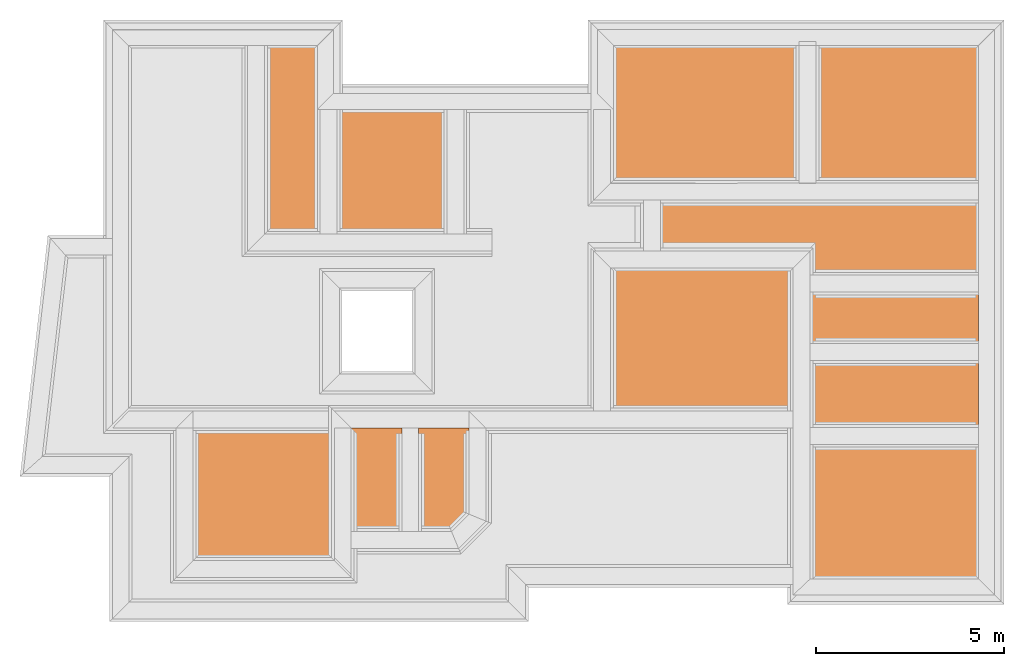
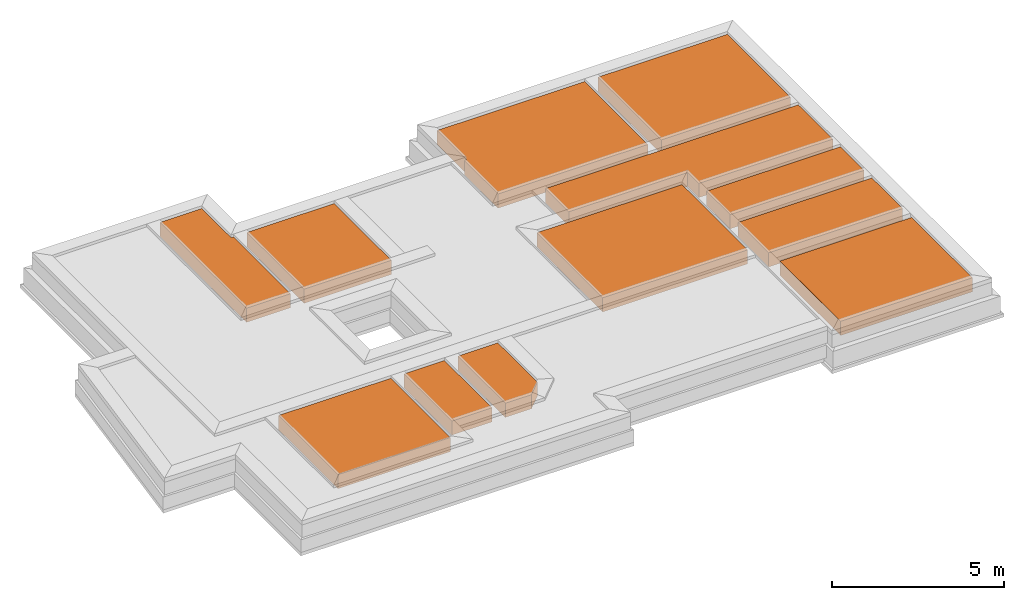
# One storey, part 5 of 6: 10 earthworks fills, 2 built elements.
"""IFC4X3_ADD2 building model written with IfcOpenShell, lengths in metres."""

from ifc_helpers import new_model, entity, si_unit, converted_unit, frame, origin_with_axes, origin_2d_with_axis, place, context, subcontext, project, spatial, indexed_curve, outline, extrude, polygons, material, layer, layer_set, layer_usage, type_object, element, save


model = new_model("IFC4X3_ADD2")

# Units and contexts
model_context = context("Model", 3, precision=1e-05, world=origin_with_axes())
plan_context = context("Plan", 2, precision=1e-05, world=origin_2d_with_axis())
body_context = subcontext(model_context, "Body", "Model", "MODEL_VIEW")
ifc_project = project(units=[si_unit("VOLUMEUNIT", "CUBIC_METRE"), si_unit("LENGTHUNIT", "METRE"), converted_unit("PLANEANGLEUNIT", "degree", entity("IfcReal", 0.0174532925199433), si_unit("PLANEANGLEUNIT", "RADIAN"), dimensions=[0, 0, 0, 0, 0, 0, 0]), si_unit("AREAUNIT", "SQUARE_METRE")], contexts=[model_context, plan_context])

# Site, building, storey
site_placement = place(None, origin_with_axes())
site = spatial("IfcSite", under=ifc_project, at=site_placement)
building_placement = place(site_placement, origin_with_axes())
building = spatial("IfcBuilding", under=site, at=building_placement, Name="Building")
storey_placement = place(building_placement, frame((0.0, 0.0, -0.870000004768372), z_axis=(0.0, 0.0, 1.0), x_axis=(1.0, 0.0, 0.0)))
storey = spatial("IfcBuildingStorey", under=building, at=storey_placement, Name="Footing")

# Built element
ifc_material = material(Name="Brick")
ifc_layer = layer(ifc_material, 0.5)
ifc_layer_set = layer_set([ifc_layer])
ifc_layer_usage = layer_usage(ifc_layer_set, "AXIS3", "POSITIVE", -0.100000001490116)
built_element_type = type_object("IfcBuiltElementType", Name="EarthFill", material=ifc_layer_set)
built_element_1_placement = place(storey_placement, frame((26.6491851806641, 12.8797168731689, 0.820000022649765), z_axis=(0.0, 0.0, 1.0), x_axis=(1.0, 0.0, 0.0)))
element("IfcBuiltElement", 1, at=built_element_1_placement, inside=storey, type_object=built_element_type, material=ifc_layer_usage, Name="BuiltElement", context=body_context, shape_type="SweptSolid", body=[
    extrude(outline(indexed_curve([(1.61248397827148, -1.09536957740784), (1.61248397827148, 2.42463111877441), (-2.79917144775391, 2.42463111877441), (-2.79917144775391, -1.09536957740784), (1.61248397827148, -1.09536957740784)])), frame((0.0, 0.0, -0.100000001490116), z_axis=(0.0, 0.0, 1.0), x_axis=(1.0, 0.0, 0.0)), (0.0, 0.0, 1.0), 0.5),
])

# Earthworks fill
earthworks_fill_1_placement = place(storey_placement, frame((20.5324192047119, 25.557674407959, 0.719999670982361), z_axis=(0.0, 0.0, 1.0), x_axis=(1.0, 0.0, 0.0)))
element("IfcEarthworksFill", 2, at=earthworks_fill_1_placement, inside=storey, Name="Slab", PredefinedType="BACKFILL", context=body_context, shape_type="Tessellation", body=[
    polygons([(3.2425971031189, -7.49831056594849, 0.500000357627869), (3.24265813827515, -6.12808227539062, 0.500000357627869), (7.72924995422363, -6.12808227539062, 0.500000357627869), (3.2425971031189, -7.49831056594849, 0.0), (7.72924995422363, -7.49831056594849, 0.500000357627869), (7.72924995422363, -7.49831056594849, 0.0), (7.72924995422363, -6.12808227539062, 0.0), (3.24265813827515, -6.12808227539062, 0.0)], [[[5, 6, 4, 1]], [[2, 8, 7, 3]], [[1, 4, 8, 2]], [[3, 7, 6, 5]], [[3, 5, 1, 2]], [[6, 7, 8, 4]]]),
])

# Built element
built_element_2_placement = place(storey_placement, frame((5.8589391708374, 28.8824787139893, 0.719999670982361), z_axis=(0.0, 0.0, 1.0), x_axis=(1.0, 0.0, 0.0)))
element("IfcBuiltElement", 3, at=built_element_2_placement, inside=storey, Name="Slab", context=body_context, shape_type="Tessellation", body=[
    polygons([(4.80036449432373, -2.89457559585571, 0.0), (4.80036449432373, -2.89457559585571, 0.500000357627869), (3.39926075935364, -2.89457559585571, 0.500000357627869), (3.39926075935364, -2.89457559585571, 0.0), (3.39919972419739, -7.90809297561646, 0.500000357627869), (3.39919972419739, -7.90809297561646, 0.0), (4.87536239624023, -7.90809297561646, 0.500000357627869), (4.87536239624023, -7.90809297561646, 0.0), (4.87536239624023, -4.59257173538208, 0.500000357627869), (4.87536239624023, -4.59257173538208, 0.0), (4.80036449432373, -4.59257173538208, 0.500000357627869), (4.80036449432373, -4.59257173538208, 0.0)], [[[2, 1, 12, 11]], [[7, 5, 3, 2, 11, 9]], [[3, 4, 1, 2]], [[11, 12, 10, 9]], [[12, 1, 4, 6, 8, 10]], [[7, 8, 6, 5]], [[9, 10, 8, 7]], [[5, 6, 4, 3]]]),
])

# Earthworks fills
earthworks_fill_2_placement = place(storey_placement, frame((15.224084854126, 25.9791069030762, 0.719999670982361), z_axis=(0.0, 0.0, 1.0), x_axis=(1.0, 0.0, 0.0)))
element("IfcEarthworksFill", 4, at=earthworks_fill_2_placement, inside=storey, Name="Slab", PredefinedType="BACKFILL", context=body_context, shape_type="Tessellation", body=[
    polygons([(3.2425971031189, -9.71308326721191, 0.500000357627869), (3.24265813827515, -5.90621185302734, 0.500000357627869), (8.10093116760254, -5.90621185302734, 0.500000357627869), (3.24265813827515, -5.90621185302734, 0.0), (8.10093116760254, -5.90621185302734, 0.0), (8.10093116760254, -9.71308326721191, 0.0), (8.10093116760254, -9.71308326721191, 0.500000357627869), (3.2425971031189, -9.71308326721191, 0.0)], [[[6, 7, 3, 5]], [[8, 1, 7, 6]], [[5, 3, 2, 4]], [[3, 7, 1, 2]], [[4, 2, 1, 8]], [[6, 5, 4, 8]]]),
])
earthworks_fill_3_placement = place(storey_placement, frame((15.7524299621582, 30.2359886169434, 0.719999670982361), z_axis=(0.0, 0.0, 1.0), x_axis=(1.0, 0.0, 0.0)))
element("IfcEarthworksFill", 5, at=earthworks_fill_3_placement, inside=storey, Name="Slab", PredefinedType="BACKFILL", context=body_context, shape_type="Tessellation", body=[
    polygons([(2.78925061225891, -4.23808860778809, 0.500000357627869), (2.78925061225891, -4.23808860778809, 0.0), (7.72924995422363, -4.23808860778809, 0.0), (7.72924995422363, -4.23808860778809, 0.500000357627869), (7.72924995422363, -7.90809297561646, 0.0), (7.72924995422363, -7.90809297561646, 0.500000357627869), (2.71425199508667, -7.90809297561646, 0.0), (2.71425199508667, -7.90809297561646, 0.500000357627869), (2.71426725387573, -5.94608306884766, 0.0), (2.71426725387573, -5.94608306884766, 0.500000357627869), (2.78922009468079, -5.94608306884766, 0.0), (2.78922009468079, -5.94608306884766, 0.500000357627869)], [[[3, 2, 11, 9, 7, 5]], [[2, 1, 12, 11]], [[5, 6, 4, 3]], [[3, 4, 1, 2]], [[11, 12, 10, 9]], [[7, 8, 6, 5]], [[6, 8, 10, 12, 1, 4]], [[9, 10, 8, 7]]]),
])
earthworks_fill_4_placement = place(storey_placement, frame((20.5324192047119, 30.2359886169434, 0.719999670982361), z_axis=(0.0, 0.0, 1.0), x_axis=(1.0, 0.0, 0.0)))
element("IfcEarthworksFill", 6, at=earthworks_fill_4_placement, inside=storey, Name="Slab", PredefinedType="BACKFILL", context=body_context, shape_type="Tessellation", body=[
    polygons([(3.39919972419739, -7.90809297561646, 0.500000357627869), (3.39926075935364, -4.23808860778809, 0.500000357627869), (7.72924995422363, -4.23808860778809, 0.500000357627869), (3.39919972419739, -7.90809297561646, 0.0), (7.72924995422363, -7.90809297561646, 0.500000357627869), (7.72924995422363, -7.90809297561646, 0.0), (7.72924995422363, -4.23808860778809, 0.0), (3.39926075935364, -4.23808860778809, 0.0)], [[[1, 4, 8, 2]], [[2, 8, 7, 3]], [[3, 5, 1, 2]], [[5, 6, 4, 1]], [[3, 7, 6, 5]], [[6, 7, 8, 4]]]),
])
earthworks_fill_5_placement = place(storey_placement, frame((30.3727493286133, 25.2770919799805, 0.720000624656678), z_axis=(0.0, 0.0, 1.0), x_axis=(7.54979012640431e-08, -0.999999999999997, 0.0)))
element("IfcEarthworksFill", 7, at=earthworks_fill_5_placement, inside=storey, Name="Slab", PredefinedType="BACKFILL", context=body_context, shape_type="Tessellation", body=[
    polygons([(5.39749765396118, -6.59773302078247, 0.500000357627869), (5.39749765396118, -6.59773302078247, 0.0), (4.75419616699219, -6.59773302078247, 0.0), (4.75419616699219, -6.59773302078247, 0.500000357627869), (4.75419616699219, -10.5810642242432, 0.0), (4.75419616699219, -10.5810642242432, 0.500000357627869), (3.39919948577881, -10.5810642242432, 0.0), (3.39919948577881, -10.5810642242432, 0.500000357627869), (3.39926075935364, -2.11107873916626, 0.0), (3.39926075935364, -2.11107873916626, 0.500000357627869), (5.39749765396118, -2.11107873916626, 0.0), (5.39749765396118, -2.11107873916626, 0.500000357627869)], [[[2, 1, 12, 11]], [[3, 4, 1, 2]], [[5, 6, 4, 3]], [[7, 8, 6, 5]], [[8, 10, 12, 1, 4, 6]], [[9, 10, 8, 7]], [[9, 7, 5, 3, 2, 11]], [[11, 12, 10, 9]]]),
])
earthworks_fill_6_placement = place(storey_placement, frame((3.95439720153809, 20.269115447998, 0.719999670982361), z_axis=(0.0, 0.0, 1.0), x_axis=(1.0, 0.0, 0.0)))
element("IfcEarthworksFill", 8, at=earthworks_fill_6_placement, inside=storey, Name="Slab", PredefinedType="BACKFILL", context=body_context, shape_type="Tessellation", body=[
    polygons([(3.39919972419739, -7.90809297561646, 0.500000357627869), (3.39926075935364, -4.45309543609619, 0.500000357627869), (7.15860080718994, -4.45309543609619, 0.500000357627869), (3.39919972419739, -7.90809297561646, 0.0), (7.15860080718994, -7.90809297561646, 0.500000357627869), (7.15860080718994, -7.90809297561646, 0.0), (7.15860080718994, -4.45309543609619, 0.0), (3.39926075935364, -4.45309543609619, 0.0)], [[[6, 7, 8, 4]], [[3, 5, 1, 2]], [[2, 8, 7, 3]], [[5, 6, 4, 1]], [[3, 7, 6, 5]], [[1, 4, 8, 2]]]),
])
earthworks_fill_7_placement = place(storey_placement, frame((7.7851037979126, 28.8824787139893, 0.719999670982361), z_axis=(0.0, 0.0, 1.0), x_axis=(1.0, 0.0, 0.0)))
element("IfcEarthworksFill", 9, at=earthworks_fill_7_placement, inside=storey, Name="Slab", PredefinedType="BACKFILL", context=body_context, shape_type="Tessellation", body=[
    polygons([(3.39919972419739, -7.90809297561646, 0.500000357627869), (3.39926075935364, -4.59257173538208, 0.500000357627869), (6.32511425018311, -4.59257173538208, 0.500000357627869), (3.39926075935364, -4.59257173538208, 0.0), (6.32511425018311, -4.59257173538208, 0.0), (6.32511425018311, -7.90809297561646, 0.0), (6.32511425018311, -7.90809297561646, 0.500000357627869), (3.39919972419739, -7.90809297561646, 0.0)], [[[6, 5, 4, 8]], [[8, 1, 7, 6]], [[5, 3, 2, 4]], [[6, 7, 3, 5]], [[3, 7, 1, 2]], [[4, 2, 1, 8]]]),
])
earthworks_fill_8_placement = place(storey_placement, frame((7.53807640075684, 20.269115447998, 0.719999670982361), z_axis=(0.0, 0.0, 1.0), x_axis=(1.0, 0.0, 0.0)))
element("IfcEarthworksFill", 10, at=earthworks_fill_8_placement, inside=storey, Name="Slab", PredefinedType="BACKFILL", context=body_context, shape_type="Tessellation", body=[
    polygons([(7.15860080718994, -4.45309543609619, 0.0), (7.15860080718994, -4.45309543609619, 0.500000357627869), (5.82094097137451, -4.45309543609619, 0.500000357627869), (5.82094097137451, -4.45309543609619, 0.0), (5.82087993621826, -7.2118935585022, 0.500000357627869), (5.82087993621826, -7.2118935585022, 0.0), (6.69451379776001, -7.2118935585022, 0.500000357627869), (6.69451379776001, -7.2118935585022, 0.0), (7.15859985351562, -6.74780654907227, 0.500000357627869), (7.15859985351562, -6.74780654907227, 0.0)], [[[4, 6, 8, 10, 1]], [[5, 3, 2, 9, 7]], [[5, 6, 4, 3]], [[7, 8, 6, 5]], [[3, 4, 1, 2]], [[9, 10, 8, 7]], [[2, 1, 10, 9]]]),
])
earthworks_fill_9_placement = place(storey_placement, frame((5.75035619735718, 20.269115447998, 0.719999670982361), z_axis=(0.0, 0.0, 1.0), x_axis=(1.0, 0.0, 0.0)))
element("IfcEarthworksFill", 11, at=earthworks_fill_9_placement, inside=storey, Name="Slab", PredefinedType="BACKFILL", context=body_context, shape_type="Tessellation", body=[
    polygons([(5.81258201599121, -7.2118935585022, 0.500000357627869), (5.81264305114746, -4.45309543609619, 0.500000357627869), (7.15860080718994, -4.45309543609619, 0.500000357627869), (5.81264305114746, -4.45309543609619, 0.0), (7.15860080718994, -4.45309543609619, 0.0), (7.15860080718994, -7.2118935585022, 0.0), (7.15860080718994, -7.2118935585022, 0.500000357627869), (5.81258201599121, -7.2118935585022, 0.0)], [[[6, 5, 4, 8]], [[8, 1, 7, 6]], [[5, 3, 2, 4]], [[6, 7, 3, 5]], [[3, 7, 1, 2]], [[4, 2, 1, 8]]]),
])
earthworks_fill_10_placement = place(storey_placement, frame((20.5324192047119, 23.7374439239502, 0.719999670982361), z_axis=(0.0, 0.0, 1.0), x_axis=(1.0, 0.0, 0.0)))
element("IfcEarthworksFill", 12, at=earthworks_fill_10_placement, inside=storey, Name="Slab", PredefinedType="BACKFILL", context=body_context, shape_type="Tessellation", body=[
    polygons([(3.2425971031189, -7.90809297561646, 0.500000357627869), (3.24265813827515, -6.12808227539062, 0.500000357627869), (7.72924995422363, -6.12808227539062, 0.500000357627869), (3.24265813827515, -6.12808227539062, 0.0), (7.72924995422363, -6.12808227539062, 0.0), (7.72924995422363, -7.90809297561646, 0.0), (7.72924995422363, -7.90809297561646, 0.500000357627869), (3.2425971031189, -7.90809297561646, 0.0)], [[[5, 3, 2, 4]], [[8, 1, 7, 6]], [[3, 7, 1, 2]], [[6, 7, 3, 5]], [[4, 2, 1, 8]], [[6, 5, 4, 8]]]),
])

save(model, "model.ifc")
